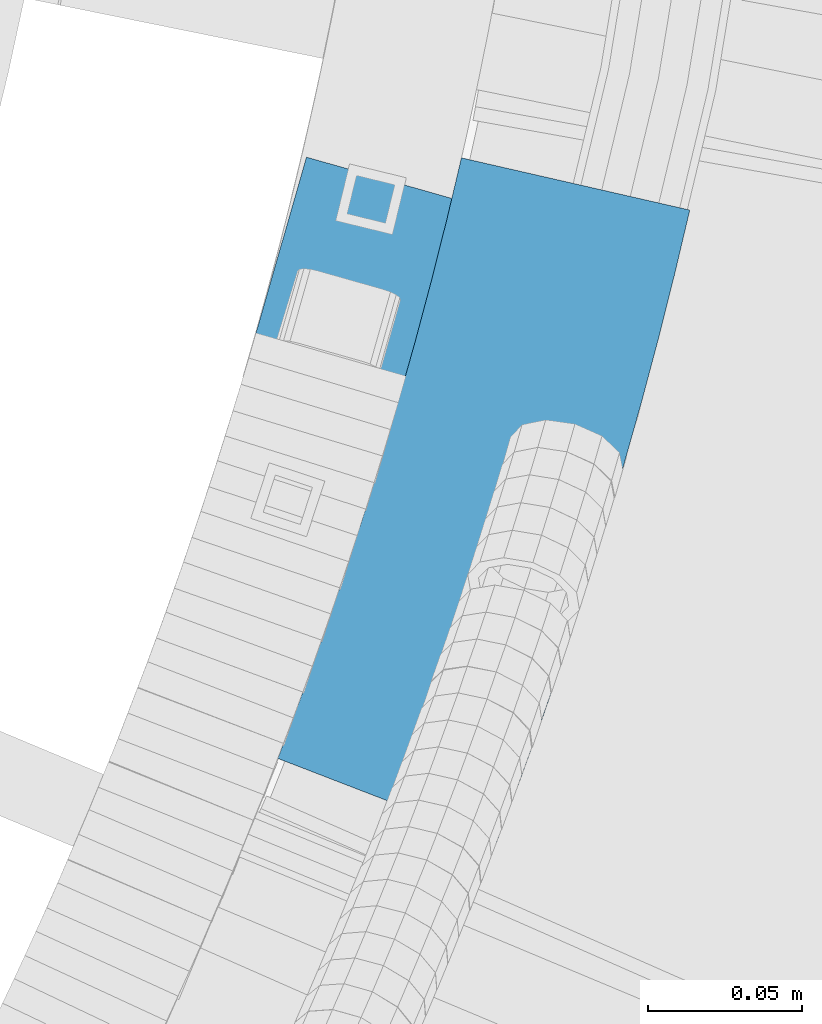
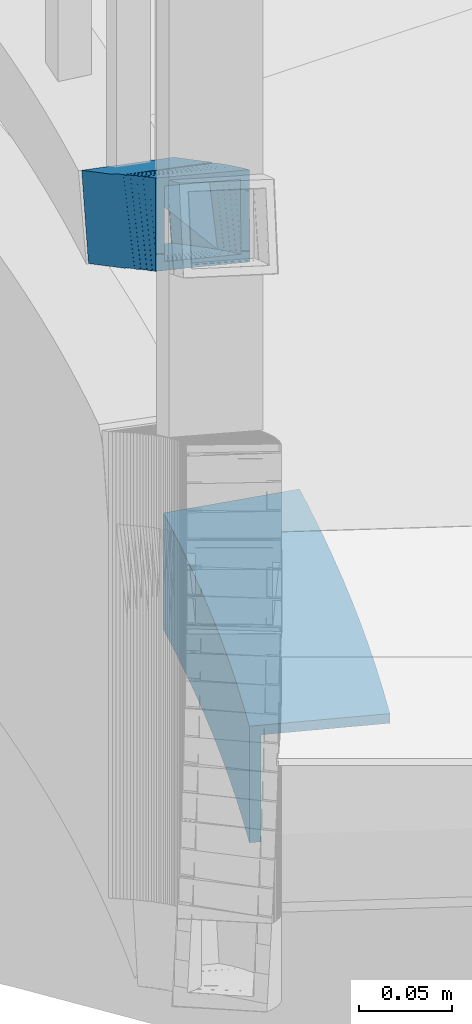
# One storey, part 494 of 975: 1 beam, 1 member.
"""IFC2X3 building model written with IfcOpenShell, lengths in millimetres."""

from ifc_helpers import new_model, si_unit, frame, origin_with_axes, place, context, subcontext, project, spatial, faceted_brep, material, type_object, element, save


model = new_model("IFC2X3")

# Units and contexts
model_context = context("Model", 3, precision=1e-05, world=origin_with_axes())
body_context = subcontext(model_context, "Body", "Model", "MODEL_VIEW")
ifc_project = project(units=[si_unit("LENGTHUNIT", "METRE", prefix="MILLI"), si_unit("AREAUNIT", "SQUARE_METRE"), si_unit("VOLUMEUNIT", "CUBIC_METRE"), si_unit("MASSUNIT", "GRAM", prefix="KILO"), si_unit("TIMEUNIT", "SECOND"), si_unit("PLANEANGLEUNIT", "RADIAN"), si_unit("SOLIDANGLEUNIT", "STERADIAN"), si_unit("THERMODYNAMICTEMPERATUREUNIT", "DEGREE_CELSIUS"), si_unit("LUMINOUSINTENSITYUNIT", "LUMEN")], contexts=[model_context])

# Site, building, storey
site_placement = place(None, origin_with_axes())
site = spatial("IfcSite", under=ifc_project, at=site_placement, CompositionType="ELEMENT")
building_placement = place(site_placement, origin_with_axes())
building = spatial("IfcBuilding", under=site, at=building_placement, Name="Undefined", CompositionType="ELEMENT")
storey_placement = place(building_placement, origin_with_axes())
storey = spatial("IfcBuildingStorey", under=building, at=storey_placement, Name="Undefined", CompositionType="ELEMENT", Elevation=0.0)

# Member
ifc_material_1 = material()
member_type = type_object("IfcMemberType", Name="HSS2X2X.188_TUBES", PredefinedType="NOTDEFINED")
member_placement = place(storey_placement, frame((36058.6682206179, 2958.69958421082, 2375.71879343567), z_axis=(0.95087143147721, -0.309586047490001, 4.0258373701363e-10), x_axis=(-0.260603277001165, -0.800424350003793, 0.539821074002544)))
element("IfcMember", 1, at=member_placement, inside=storey, type_object=member_type, material=ifc_material_1, Name="HANDRAIL", ObjectType="HSS2X2X.188_TUBES", context=body_context, shape_type="Brep", body=[
    faceted_brep([(85.1909390580277, -20.7696041309646, 18.6765739419134), (85.1843664568114, -14.2400431348069, 18.4890902299958), (89.372431475711, -20.7707783078004, 18.4890902346815), (86.5870745108568, -21.9558293144728, -22.6854508030738), (83.4755373449425, -21.9549555845952, -22.5459402014094), (85.105765746679, -20.8242245320762, 16.7772759879954), (83.4474729527701, -17.0600346618012, -22.6854508065881), (73.2920638491851, -21.643966446667, -22.0919903583708), (62.6296669214062, -21.5914426805666, -21.7448117184031), (63.9768686473708, -20.7275018938362, 19.4991487951556), (74.5513523739428, -20.7795925929222, 19.1548326996854), (74.5502534711177, -20.7801463676842, 19.1283485368185), (74.6383750251989, -20.7805967566092, 19.1247063785704), (64.1435749368338, 18.5945900370571, 18.6700202242719), (74.4250307848615, 2.56201531871739, 18.6700202279899), (74.4185663200496, 2.55106416215494, 18.5133816507441), (73.290057466771, -21.9016800830505, -22.114620653083), (83.4754059197603, -21.855356416494, -22.5382081810531), (83.4483317206668, -17.0585798599532, -22.6646422012054), (73.3733969314217, -1.34804750369585, -22.6646422147605), (74.638267721486, -20.8070605830308, 19.1254145587445), (85.1848827854228, -20.7590938510348, 18.6868027013261), (85.1477469286856, -14.1796782834754, 18.513381665216), (73.3781592835894, -1.33607885985111, -22.5201936656158), (62.7855668053508, 15.1816724079199, -22.5201936694502), (62.628873559408, 14.7878742199428, -27.2729106571787), (62.454034583885, -26.4525270323775, -26.4033334481937), (64.1121290158371, -25.3892152948647, 24.358464106961), (64.3002681827747, 18.9883882250324, 23.4227372120076), (72.5289680790866, -0.650017791800565, -27.2729106535917), (72.5230647418739, -0.660018365455471, -27.415952661795), (72.6677613303273, -26.2961304751861, -26.740232899414), (72.8007416245855, -26.5034956864438, -26.7402328998505), (72.6689279485927, -26.5028219872493, -26.7347848993959), (72.6705544138586, -26.7909852834255, -26.7271894561709), (74.774525943616, -25.4417390609651, 24.0112854670006), (74.8928606610134, 2.4706369572632, 23.4227372158348), (74.887650040926, 2.45754173585556, 23.2646920974512), (85.3438332988408, -13.8474973323446, 23.264692111341), (85.4090010929885, -25.3933727219337, 23.5690196969663), (85.3974666345948, -13.9344469258194, 23.2399988111501), (92.7472297058175, -25.3954333206857, 23.2399988193793), (83.1243980715662, -17.1941398216914, -27.4363593878661), (83.1253134080616, -17.192827183826, -27.4159526474905), (89.3190980567706, -26.8539576365893, -27.4363593809321), (83.1341198147784, -26.8522208743379, -27.1590462749518), (83.1340102687827, -26.7433922336695, -27.162171078824), (83.1847692866704, -26.7431659097347, -27.1644538568071), (83.1339302416145, -26.663889117046, -27.1644538570181), (51.8441843637811, -26.0925731607895, -26.0643109739613), (51.8456197991018, -26.4841812515151, -26.0561548129917), (53.5037142165038, -25.4208695075067, 24.7056427429998), (63.9474467026939, 19.5385667782029, 23.4227372165187), (60.1960984104935, 25.3882997998953, 23.4227372123278), (53.5665815768753, 25.3685181279743, 23.6396995601026), (51.6719750990324, 24.3124925469056, -26.73063740004), (51.6594545590633, 24.3044633073387, -27.1139479749472), (51.843149890763, -25.8103535455957, -26.0701888622498), (52.5250634735276, 24.3152517441958, -26.7482963453003), (56.5167295814663, 24.3189568252419, -27.2729106594197), (52.0243446479217, -26.0929028673927, -26.0701888622643), (62.3009942566168, 15.299158757769, -27.2729106529732), (62.455349173435, 15.6966032596829, -22.5201936652156), (62.5920279778948, -21.5914061291442, -21.7435830331015), (63.9392296725709, -20.7274653423665, 19.5003774813595), (63.7930917858739, 19.1411222762872, 18.6700202287466), (62.8987982159997, 20.5356551800069, 18.6700202277498), (59.9093110424146, 19.6668140131023, -22.5201936680533), (53.3318635353226, -20.7217304042624, 19.883008736826), (53.1909164933968, 20.5499242483929, 19.3391887806065), (51.8424911728198, 20.0041418235342, -21.9131526543206), (51.8437006390504, 19.6499898537022, -21.9084861365845), (53.1795555943772, 20.506654142122, 18.9880991693499), (53.3306795589251, -20.7222096250971, 19.8467873770642), (52.6168119806807, 19.6524903762511, -21.9244895557713), (52.6094368717677, 19.6450320764197, -22.2812927227351), (52.55835714145, -21.6213453825803, -21.415213887034), (53.411202767029, -20.7588796941873, 19.8449252805804), (53.4112479749183, -20.7223570712376, 19.8441587613779), (31.3093052156873, 20.4406211395362, -21.1126368639234), (31.6733231854414, 20.6740605650175, 20.160097743501), (21.5243876892109, 20.5785127107119, 20.2501499187201), (21.037008749925, 20.3439118948627, -21.0214900986684), (32.0639268345767, -20.5984503467153, 20.3900908510332), (21.3934873952003, -20.6989079359191, 20.4847703651976), (31.6999088648245, -20.8318897722002, -20.8826437563912), (20.983529829673, -20.9327798628983, -20.787556617157), (21.3474680553481, -20.6993915761323, 20.4761365241138), (21.3933789933435, -20.6989601153655, 20.4755908089428), (20.9538765718989, 25.3623185901506, 24.9908858250274), (20.9530288038368, 25.3617749288314, 24.8947650035989), (21.4346195246817, -25.4346179166005, 25.273954265067), (42.9560500855441, 25.3909811661524, 24.1475024120009), (32.4630791062827, 25.4592838163444, 24.3961960057859), (32.150998569814, -25.3337278255949, 25.178867123228), (42.7873351813068, -25.4029636889354, 24.9267756332338), (42.8561748845441, 25.3911522082835, 24.1498768633173), (42.8513105204129, 25.3880327625593, 23.9143962278467), (41.8090811184884, 24.6171227157447, -26.5309333764453), (41.8932922790664, 24.6165786147194, -26.5326657331316), (41.8908423464618, 24.6150075087353, -26.6356026870562), (31.254505746374, 24.6842433790662, -26.3835111889566), (41.5787618099966, -26.1780041332022, -25.8529315696214), (30.9424252099088, -26.1087682628695, -25.6008400715218), (30.9453781973771, -25.6281515329501, -25.6082459098616), (31.1694421837183, -25.6260608831726, -25.6136106139456), (30.9475173076316, -25.2799982857905, -25.6136106142148), (20.986597408064, -25.7219279787314, -25.5232575594637), (31.6702556070504, 25.4632086808506, 24.8957986858004), (20.5058544552794, 25.0750085280179, -25.8063259994815), (20.5067431948974, 24.981101275429, -25.8058026966901), (20.9349325403291, 25.3501700584457, 22.8429918955881), (31.2222334904309, 25.1758986187178, -25.901413138723), (21.2664451055298, 25.3647203454057, 24.891039616261), (20.8728784055929, -13.705991156965, -25.5902169614492), (20.9955591823364, 24.9795294917003, -25.8101050742334), (31.2502520708895, 22.215360051734, -25.8849153911942), (10.3040858872137, 25.0134069994092, -25.7817800186676), (10.1462176635378, -25.1277620030451, -25.4000000000597), (10.3085966870822, 25.0162997096049, -25.4000000000087), (20.9944045946904, 24.9787890714742, -25.9078257680812), (10.7443008148512, 25.0149279059915, -25.4000000000015), (10.7443008148275, 25.2957104147681, 11.4766371525693), (10.9042379470629, 25.3982757660124, 25.0132167189877), (10.7443008391474, -25.3999999803054, 25.4000000159358), (10.1441487792981, -25.7848687469068, -25.3949967217195), (20.8344674867767, -25.8194866748399, -25.5210424711331), (10.1453605289753, -25.3999999999978, -25.397927151942), (10.3207999221213, -25.3999999999978, -25.4000000000597), (0.0, 25.3999999999724, -25.4000000000342), (1.2732925824821e-11, 25.3051002816392, -25.4000000000378), (-2.18278728425503e-11, 25.3999999999869, 25.0401471488367), (-10.5679539465345, 25.3557880582484, -25.4643129099131), (-10.8083039031917, -24.6357178351973, -25.370257279872), (-10.5665843539682, 25.3566663581878, -24.9939878685545), (20.5929637581012, 20.2539657761263, -21.1043140418769), (10.7443008148493, 20.2858582120152, -20.9881919565232), (10.7443008148566, -20.9881616389357, -20.6754627090631), (20.9057258462526, -21.021066876754, -20.7952724610586), (20.9253104442905, -14.8007229901013, -20.8426347992863), (0.0875273161273071, 20.5510763158873, -20.6375000000262), (0.207468504937424, 20.6279928687254, 20.5509132241932), (-10.456789874901, 20.6793229062114, 20.5818718263254), (-10.5757412930725, 20.6030410789954, -20.2666491357959), (-10.2781924243536, 20.6016170200128, -20.2631936834732), (-10.2731638156674, 20.6007827560279, -20.6937631977853), (9.09494701772928e-12, 20.5513351653008, -20.7235864428585), (9.09494701772928e-12, 20.5514971311077, -20.6375000000262), (-7.27595761418343e-12, -20.6522469299762, 17.5281188893059), (-0.111164062889657, -20.7235348386694, -20.6461847268583), (-10.1417332690216, -20.6752549231751, -20.6170657398616), (-10.6238003142407, -20.5952782936383, 20.6594356657079), (-1.09139364212751e-11, -20.6464135952192, 20.6285945143391), (1.2732925824821e-11, 2.39799587925881, -20.6896863197835), (-1.09139364212751e-11, -20.6375000000044, 20.6285778688034), (0.0, -20.6375000000153, -20.6375000000153), (1.45519152283669e-11, 5.2389197220582, -25.4000000000524), (0.0, -25.400000000016, -25.4000000000196), (0.0, -25.399999999976, 25.4000000000378), (10.7035700606884, -20.6375000000116, 20.6375000000626), (0.0090975902548962, -20.6375000000044, 20.6375000000335), (0.20776562892388, 20.637499999988, 20.6375000000771), (10.7443008148221, 20.6374999999807, 20.637500000099), (10.7443008148257, -8.05948712242025, 20.6375000000771), (10.7443008148275, -20.6375000000116, 20.6009459134075), (10.7443008148566, -20.6375000000007, -20.6375000000407), (0.00907161240138521, -20.6375000000044, 20.628551452166), (10.7031447978261, -20.6375000000116, 20.6014321791808), (10.7443008148275, -20.6738767189581, 20.6012215362862), (10.744300814853, 20.2885284166478, -20.6374999999971), (10.3494439513215, 20.2897716136649, -20.6374999999971), (10.3505699828747, 20.6374999999935, -20.6374999999898), (0.0879432973233634, 20.6375000000007, -20.6375000000262), (10.7443008148275, 20.6374999999825, 12.7559947902191), (-10.6239431577833, -20.5504179812815, 20.6593523081028), (-10.6550153736152, -20.5505209643288, 20.6594429831021), (-10.8121877390167, -25.4435349212654, -25.3687374267902), (-10.6642583710964, -25.3486699532186, 25.4309586114905), (-10.8099187961288, -24.9716069321566, -25.3696253273083), (-21.6298011319632, 25.4150339108164, 25.682438672884), (-21.6287561402187, 25.415704048688, 25.5927306503145), (-21.4625412938931, -25.3832878961675, 25.3049128607236), (-10.8315182098777, 25.44965185613, 25.8084844262921), (-20.8708383800476, -25.0038374999604, -25.4902237674396), (-10.5933634094308, -24.9708891998398, -25.3702572796974), (-21.3824672894934, -20.5741279225313, 17.1241930513279), (-21.4226239146519, -20.5937356752238, 20.5697782314382), (-21.42265148769, -20.5853087343912, 20.5698259769488), (-20.9419911380392, -20.2770683052004, -20.6927866636615), (-21.0776220182834, 20.9152536595284, -20.3866512589666), (-21.0766732942575, 20.9157169042846, -20.4680552473583), (-21.0134374104528, 1.5894098774952, -20.5775545641955), (-20.9674867850426, 4.34915503934099, -25.2720765540435), (-32.1313067239462, -20.5770384794214, 20.4747758715966), (-32.0690412009008, 20.6972421127684, 20.7103806287341), (-21.3508007138153, 20.6805300144406, 20.80546777977), (-21.0465478851638, -20.3587077457232, -20.7028403559234), (-31.6598628860465, -20.3421592493451, -20.7969966577657), (-32.1007077765789, -20.5574158242052, 17.0291059004812), (-31.7025228492021, 20.9322849447944, -20.562322749829), (-32.1807817864155, -25.3665757976014, 25.2098257125253), (-32.1041472965153, 25.4325387774006, 25.4998007982431), (-31.6530477867327, 25.7218222629726, -25.2973725907577), (-31.7294494322814, -24.9229455288332, -25.586466623281), (-31.6857272722045, 4.3658671330486, -25.3671636970321), (-31.7316778975401, 1.606121975934, -20.6726417152313), (-32.1409902427349, -20.5686596486212, 20.4831747038115), (-31.6602316252356, -20.2603562017011, -20.7878738065701), (-42.008370110525, -20.2935310402154, -20.9086651324978), (-42.8531681251225, -20.6030015519391, 20.3581340337696), (-31.7961302436706, 21.0132802664739, -20.4811340841916), (-32.2768888611645, 20.7049768195538, 20.7899144261901), (-43.07517178325, 20.6703588742421, 20.6638686727747), (-42.5974128864127, 20.97673864432, -20.3496667898798), (-41.7674862465174, 20.9793445469259, -20.3326138734847), (-41.7620643361406, 20.981330727469, -20.597464030383), (-52.4666938933588, 26.12757556615, -25.2482260164252), (-52.7609764475183, -24.1736832686802, -25.9157388076856), (-52.4726417210841, 26.1237613113935, -24.95817590761), (-42.5546216273997, 25.7765784652111, -25.3338308516104), (-42.3889996191901, -24.5243196364681, -25.7076598824278), (-42.5579316639851, 25.7744557873193, -25.0496785235373), (-42.8218383615094, 25.398168331134, 25.4650934255114), (-32.348041619156, 25.4317460143156, 25.5873515299609), (-31.7563387053124, 25.8111964105246, -25.2077850982023), (-41.6421505427516, 25.7773312660629, -25.0308615123213), (-42.6710502173264, 25.40041974011, 25.2289585859617), (-31.7296822766348, -25.0772923120312, -25.5873476764682), (-31.7295469333312, -24.987576574229, -25.5868355547718), (-42.9790647031732, -25.4011937379837, 25.0837799643996), (-42.3873617893278, -25.0217433417765, -25.7113566637709), (-31.6880882684181, -24.9874428082258, -25.5864666232301), (-42.3883203762507, -24.7306118455945, -25.709193016417), (-52.7638630336605, -24.667082943768, -25.9222863693576), (-53.8052694179623, -25.3349215964899, 24.8626470687886), (-52.7621660319928, -24.3770170911703, -25.9184371084993), (-42.2561987053432, -24.7314051555477, -25.7076598823187), (-53.5081002776606, 25.4597369134281, 25.5367074217211), (-42.6818955759536, 25.3934647705591, 25.7578403215157), (-42.6759271673782, 25.3972922235116, 25.4667865726151), (-41.6404891916518, 26.0613034232792, -25.0270931166306), (-52.3450519774215, 26.1229652397669, -24.9544366994378), (-52.7662551067806, 25.9354713499724, -10.6399073873035), (-52.6306049839422, -24.3769803650503, -25.91573880738), (-148.36852020388, 26.403354666747, -27.7745622173534), (-150.048616437696, 25.4453572875445, 22.9889506606996), (-53.8390841225573, 25.4560446140331, 25.8200433926322), (-52.3452457515723, 26.414021302995, -24.948950369384), (-133.652967455984, -24.3859806420478, -28.2999289806321), (-135.333063689799, -25.3439780212502, 22.4635838974282), (-53.6696186965764, -18.6412059819104, 20.2275357787148), (-53.6958666462342, 20.7842018461579, 20.9706943221972), (-52.8597819034785, 21.3203707578105, -7.44414754693571), (-53.6801795843458, -20.4834595112679, 20.1924629505302), (-136.555137737996, -20.4926655817508, 17.7537576991672), (-148.51152434566, 20.7736693566458, 18.1806181943248), (-135.19005954802, -19.714292711149, -23.4915965142573), (-147.146446155682, 21.5520422272475, -23.0647360190997), (-52.5960676927043, 21.5625452485183, -20.282466083605), (-53.4383280360362, 20.7603475518154, 20.7124267538093), (-53.6796178438617, -20.4829436527725, 20.1651159096946), (-52.5975755676664, 21.2995097887797, -20.2874737534803), (-53.6675845848495, -20.4829402936102, 20.1653627103806), (-52.4546485181017, -19.7051021421012, -21.0569976215702), (-52.4819473619846, 21.298788348864, -20.2840850960492), (-43.0782938553093, 20.6969290515881, 20.9240377905007), (-52.4741840135684, 21.3022441170942, -20.5479214038278), (-42.5983030781827, 21.2417893399725, -20.3461995401231), (-42.9396755695943, -20.576057558812, 20.3841269162149), (-53.6675709231622, -20.5103872123545, 20.1650020544694), (-52.4536407700707, -19.9700197020502, -21.0902440445061), (-42.0074305735798, -20.0339657250261, -20.8768728016366), (-42.9393639548907, -20.5757038301854, 20.3573338746428), (-42.8530083214664, -20.576222343032, 20.3583359416298), (-20.9348072996472, 25.7051101646466, -25.2022854397292), (-21.0114417895493, -25.0940044103572, -25.4922605254324), (-21.5240097434053, 25.4160420119752, 25.5936627654737), (-21.6254745836359, 25.4178084627729, 25.3110232069448), (-10.2398152960341, 25.8291022523408, -24.9866522018783), (-21.0380982181177, 25.7944843070254, -25.1126979552937), (-21.0378027828756, 25.7047579583668, -25.1133647885872), (-20.98488550605, 20.9968663229774, -20.3849613250932), (-20.9850075546838, 20.9151077911338, -20.385573500309), (-21.3515146541849, 20.6889287608719, 20.8874193910742), (-21.4131286310385, -20.5853409079955, 20.578374151788), (-10.1437082159573, -20.2424503598868, -20.5667409102462), (-10.6548877515434, -20.5508513324676, 20.7039525040964), (-10.5736757155955, 21.0302433602137, -20.2634337830241), (-10.5155817828436, 20.8798588364589, -0.0025722194914124), (-10.7603654518862, 20.72288266137, 21.0110473225141), (-10.6367904282324, -16.8079668914797, 20.7321234534902), (-10.4200245786124, 25.4506530262952, 25.3353831283603), (-10.5010486594256, 25.3986934529839, -2.48869761304377), (-10.238254567721, 25.3550949827622, -24.9901749556448), (0.0963044333020662, 25.3044580207606, -25.4952715120307), (-0.147929359181944, -25.4948649587532, -25.3996960289005), (0.0965818651693553, 25.3046359338132, -25.4000000000306), (0.0, 25.400000000016, 25.4000000000196), (-2.18278728425503e-11, 25.3999999999869, 25.3051344739361), (0.103578884953095, 25.3999999999869, 25.3048328508885), (10.7443008148184, 25.3999999999796, 25.4000000001179), (10.7443008148548, 25.3999999999942, -25.4000000000015), (10.8329795875852, 20.5998559679265, 20.2874467089205), (21.347551686702, -20.7082126994464, 20.4762023727817), (21.523298295062, 20.5652380399915, 20.1614009595069), (21.2137716012039, -20.8235216249814, 5.27675855334383), (20.5937316008076, 20.2546276019657, -21.0170754815263), (21.0367210914865, 20.253203172957, -21.0209745112006), (32.0622263607929, -20.6475737442815, 20.1463251240202), (31.7037065857239, -21.2782908594872, -20.9282822053574), (31.3272275203781, 18.1519387878652, -21.5211375312429), (31.338551948571, 19.9950585786301, -21.5495382221925), (32.3205178034968, 20.6247789339159, 19.7089738735376), (32.066952367617, -20.644543025157, 20.3448941564493), (42.695438043278, -20.7040862948616, 20.0928415766684), (42.6954249765695, -20.7137277058464, 20.0929890425759), (42.9568544035847, 20.555543063585, 19.456882375438), (42.7033484373878, -20.7040998418743, 20.0926535135077), (42.6436481558867, -20.7520256766984, 17.5869200520028), (41.7213231127826, -21.3434992507755, -21.1657094373732), (41.7845490469062, 7.05573637198177, -26.2977884116845), (41.8773555279477, 4.05172843577202, -21.5570253012775), (41.8988698704361, 19.9263175421438, -21.7998280038591), (41.9771088001016, 19.9272465231079, -21.708343105005), (41.9007924368743, 19.9277396146554, -21.7067731567731), (41.9776870326896, 20.0206247598508, -21.7095920445354), (42.9591437185682, 20.5670203464651, 19.5503218021622), (42.7035784662748, -20.7039717804237, 20.1023238047055), (52.5596481527809, -21.2684756086728, -21.381222812146), (41.843269117584, -21.2505697900997, -21.1600899219266), (41.7382666438007, -26.0757160316189, -25.8579352502347), (41.8092244933323, 24.7197582019089, -26.532295965153), (52.5256035285329, 24.7018523833358, -26.753428855387), (42.8582930308403, 25.3925105445924, 24.2524149183082), (53.5746720660372, 25.3746047260192, 24.0312820280742)], [[[0, 1, 2]], [[0, 2, 3, 4, 5]], [[3, 6, 4]], [[7, 8, 9, 10, 11, 12]], [[9, 13, 14, 10]], [[10, 14, 15, 11]], [[16, 17, 18, 19]], [[20, 21, 17, 16]], [[12, 11, 15, 22, 21, 20]], [[16, 19, 23, 7, 12, 20]], [[8, 7, 23, 24]], [[9, 8, 24, 25, 26, 27, 28, 13]], [[29, 30, 31]], [[26, 25, 29, 31, 32]], [[33, 34, 35]], [[27, 26, 32, 33, 35]], [[27, 35, 36, 28]], [[36, 35, 37]], [[38, 22, 15, 14, 13, 28, 36, 37]], [[35, 39, 38, 37]], [[5, 4, 6, 18, 17, 21, 22, 38, 39]], [[40, 1, 0, 5, 39]], [[39, 41, 40]], [[42, 43, 30, 29, 25, 24, 23, 19, 18, 6, 3, 2, 1, 40, 41, 44]], [[39, 45, 44, 41]], [[42, 44, 45, 46, 47, 48]], [[42, 48, 43]], [[47, 34, 33, 32, 31, 30, 43, 48]], [[46, 39, 35, 34, 47]], [[45, 39, 46]], [[49, 50, 51]], [[51, 50, 26, 27]], [[51, 27, 52, 53, 54]], [[55, 56, 57]], [[58, 54, 53, 59, 56, 55]], [[60, 57, 56, 59, 61, 26, 50, 49]], [[27, 26, 61, 62, 63, 64, 65, 52]], [[66, 67, 62, 61, 59, 53, 52, 65]], [[68, 69, 70, 71, 72, 73]], [[74, 75, 67, 66, 72, 71]], [[76, 63, 62, 67, 75]], [[77, 64, 63, 76]], [[78, 73, 72, 66, 65, 64, 77]], [[79, 80, 81, 82]], [[80, 83, 84, 81]], [[83, 85, 86, 87, 88, 84]], [[89, 90, 91]], [[92, 93, 94, 95, 96]], [[97, 98, 99, 100, 101, 93, 92]], [[101, 100, 102, 103, 104, 105, 106]], [[94, 103, 102, 95]], [[103, 94, 104]], [[104, 94, 91, 107, 105]], [[89, 91, 94, 108]], [[109, 110, 111]], [[89, 108, 112, 109, 111, 113, 90]], [[106, 105, 107, 114, 115, 110, 109, 112, 116]], [[117, 118, 119]], [[111, 110, 115, 120, 117, 119, 121, 122, 123, 113]], [[90, 113, 123, 124, 91]], [[124, 125, 126, 91]], [[125, 124, 127]], [[117, 120, 126, 125, 127, 128, 118]], [[129, 130, 131]], [[132, 133, 134]], [[135, 136, 137, 138, 139]], [[140, 141, 142, 143, 144, 145, 146, 147]], [[148, 149, 150, 151, 152]], [[146, 145, 150, 149, 153]], [[152, 154, 155, 147, 146, 153, 156, 157, 158, 148]], [[159, 160, 161, 162, 163]], [[164, 165, 155, 154, 166, 160, 159, 167]], [[168, 137, 136, 169, 165, 164]], [[170, 171, 172, 140, 147, 155, 165, 169]], [[173, 162, 161, 172, 171]], [[160, 166, 141, 140, 172, 161]], [[154, 152, 151, 174, 175, 142, 141, 166]], [[176, 177, 178]], [[179, 180, 181]], [[179, 181, 177, 182]], [[178, 177, 181, 183, 184]], [[183, 181, 185, 186, 187, 188, 189, 190, 191, 192]], [[186, 185, 193, 194, 195, 187]], [[181, 196, 197, 198, 193, 185]], [[199, 194, 193, 198, 200, 201, 202, 203, 204, 205]], [[206, 207, 208, 209]], [[210, 211, 212, 213, 214, 215]], [[216, 217, 218]], [[219, 220, 221]], [[222, 223, 224, 219, 221, 225, 226]], [[227, 200, 228]], [[228, 200, 229, 230, 231]], [[230, 229, 232]], [[233, 234, 235]], [[232, 229, 234, 233, 236]], [[237, 234, 229, 238]], [[239, 238, 229]], [[200, 223, 222, 239, 229]], [[226, 240, 216, 218, 241, 242, 237, 238, 239, 222]], [[225, 240, 226]], [[221, 220, 236, 233, 235, 243, 217, 216, 240, 225]], [[244, 245, 246, 247]], [[218, 217, 243, 248, 244, 247, 241]], [[235, 234, 249, 248, 243]], [[245, 249, 234, 246]], [[242, 241, 247, 246, 234, 250, 251, 252]], [[253, 254, 255, 251, 250]], [[248, 249, 245, 244], [255, 254, 256, 257]], [[252, 251, 255, 257, 258]], [[259, 260, 253, 250, 234, 237, 242, 252, 258, 261]], [[262, 263, 256, 254, 253, 260]], [[261, 258, 257, 256, 263, 264]], [[265, 259, 261, 264, 266, 267]], [[268, 269, 262, 260, 259, 265]], [[270, 266, 264, 263, 262, 269]], [[213, 267, 266, 270, 271, 214]], [[212, 272, 268, 265, 267, 213]], [[273, 271, 270, 269, 268, 272]], [[212, 211, 206, 209, 273, 272]], [[208, 215, 214, 271, 273, 209]], [[207, 210, 215, 208]], [[198, 197, 205, 204, 224, 223, 200], [206, 211, 210, 207]], [[203, 231, 230, 232, 236, 220, 219, 224, 204]], [[202, 274, 275, 227, 228, 231, 203]], [[200, 227, 275, 180]], [[276, 277, 201, 200, 180]], [[179, 182, 278, 279, 277, 276, 180]], [[279, 280, 277]], [[192, 274, 202, 201, 277, 280]], [[191, 190, 196, 181, 180, 275, 274, 192]], [[189, 199, 205, 197, 196, 190]], [[281, 195, 194, 199, 189, 282]], [[283, 284, 187, 195, 281]], [[174, 285, 188, 187, 284, 286, 175]], [[151, 150, 145, 144, 285, 174]], [[143, 287, 281, 282, 189, 188, 285, 144]], [[288, 289, 283, 281, 287]], [[286, 284, 283, 289, 290]], [[287, 143, 142, 175, 286, 290, 177, 291, 292, 288]], [[293, 278, 182, 177, 290, 289, 288, 292]], [[134, 133, 184, 183, 192, 280, 279, 278, 293]], [[132, 294, 295, 176, 178, 184, 133]], [[156, 153, 149, 148, 158, 295, 294, 296]], [[177, 176, 295, 158]], [[297, 298, 158]], [[299, 291, 177, 158, 298]], [[131, 130, 296, 294, 132, 134, 293, 292, 291, 299]], [[298, 297, 300, 301, 129, 131, 299]], [[119, 118, 128, 157, 156, 296, 130, 129, 301, 121]], [[127, 124, 158, 157, 128]], [[297, 158, 124, 300]], [[163, 162, 173, 122, 121, 301, 300, 124]], [[123, 122, 173, 171, 170, 302, 167, 159, 163, 124]], [[87, 303, 168, 164, 167, 302, 304, 88]], [[305, 138, 137, 168, 303]], [[91, 126, 120, 115, 114, 139, 138, 305]], [[303, 87, 86, 306, 135, 139, 114, 107, 91, 305]], [[307, 304, 302, 170, 169, 136, 135, 306]], [[82, 81, 84, 88, 304, 307]], [[306, 86, 85, 79, 82, 307]], [[308, 309, 310, 116, 112, 108, 94], [83, 80, 79, 85]], [[93, 101, 106, 116, 310, 311, 312, 313, 308, 94]], [[314, 315, 313, 312, 316, 317]], [[318, 319, 309, 308, 313, 315]], [[95, 102, 100, 99, 320, 321, 319, 318]], [[322, 311, 310, 309, 319, 321]], [[323, 316, 312, 311, 322, 324]], [[325, 326, 327, 317, 316, 323]], [[326, 325, 70, 69]], [[76, 75, 74, 328, 78, 77]], [[70, 325, 323, 324, 329, 328, 74, 71]], [[57, 60, 330, 320, 99, 98, 331, 332, 58, 55]], [[331, 98, 97]], [[333, 334, 332, 331, 97, 92, 96]], [[333, 96, 95]], [[333, 95, 51, 334]], [[332, 334, 51, 54, 58]], [[95, 330, 60, 49, 51]], [[315, 314, 329, 324, 322, 321, 320, 330, 95, 318]], [[328, 329, 314, 317, 327, 68, 73, 78]], [[327, 326, 69, 68]]]),
])

# Beam
ifc_material_2 = material(Name="STEEL/A36")
beam_type = type_object("IfcBeamType", Name="L3X3X1/4", PredefinedType="NOTDEFINED")
beam_placement = place(storey_placement, frame((36096.8705560817, 2877.65313054303, 2044.7), z_axis=(0.956308835408503, -0.292358361124893, 0.0), x_axis=(0.292358361124894, 0.956308835408502, 0.0)))
element("IfcBeam", 2, at=beam_placement, inside=storey, type_object=beam_type, material=ifc_material_2, Name="ANGLE", ObjectType="L3X3X1/4", context=body_context, shape_type="Brep", body=[
    faceted_brep([(-2.73671066615134, 38.0999999999999, 38.0015843714209), (-2.73671066615134, 31.75, 38.0015843714209), (18.7586199473444, 31.75, 39.3943285454152), (18.7586199473444, 38.0999999999999, 39.3943285454152), (2.28059222179581, 31.75, -31.6679869761792), (2.28059222179581, -38.0999999999999, -31.6679869761792), (22.7737075112873, -38.0999999999999, -30.3401792099467), (22.7737075112873, 31.75, -30.3401792099467), (2.73671066615498, -38.0999999999999, -38.0015843714136), (2.73671066615498, 38.0999999999999, -38.0015843714136), (23.1387154716467, 38.0999999999999, -36.6796799149743), (23.1387154716467, -38.0999999999999, -36.6796799149743), (40.2717532976203, 31.75, 40.4778727166195), (40.2717532976203, 38.0999999999999, 40.4778727166195), (43.2837954886527, -38.0999999999999, -29.3071550606037), (43.2837954886527, 31.75, -29.3071550606037), (43.5576175060196, 38.0999999999999, -35.6512484948908), (43.5576175060196, -38.0999999999999, -35.6512484948908), (61.7982419218315, 31.75, 41.2519928813053), (61.7982419218315, 38.0999999999999, 41.2519928813053), (63.8066160530816, -38.0999999999999, -28.5691280877727), (63.8066160530816, 31.75, -28.5691280877727), (63.9891955195581, 38.0999999999999, -34.9165027213312), (63.9891955195581, -38.0999999999999, -34.9165027213312), (83.3336355961674, 31.75, 41.7165290036937), (83.3336355961674, 38.0999999999999, 41.7165290036937), (84.337926471524, -38.0999999999999, -28.1262508655782), (84.337926471524, 31.75, -28.1262508655782), (84.4292256420085, 38.0999999999999, -34.4755944900608), (84.4292256420085, -38.0999999999999, -34.4755944900608), (104.873482255854, 31.75, 41.8713850490967), (104.873482255854, 38.0999999999999, 41.8713850490967), (104.873482255798, -38.0999999999999, -27.9786149511201), (104.873482255798, 31.75, -27.9786149511201), (104.873482255793, 38.0999999999999, -34.3286149511332), (104.873482255793, -38.0999999999999, -34.3286149511332), (126.41332891554, 31.75, 41.7165290037519), (126.41332891554, 38.0999999999999, 41.7165290037519), (125.409038040074, -38.0999999999999, -28.12625086552), (125.409038040074, 31.75, -28.12625086552), (125.317738869575, 38.0999999999999, -34.4755944900025), (125.317738869575, -38.0999999999999, -34.4755944900025), (147.948722589874, 31.75, 41.2519928814218), (147.948722589874, 38.0999999999999, 41.2519928814218), (145.940348458515, -38.0999999999999, -28.5691280876563), (145.940348458515, 31.75, -28.5691280876563), (145.757768992025, 38.0999999999999, -34.9165027212002), (145.757768992025, -38.0999999999999, -34.9165027212002), (169.475211214081, 31.75, 40.4778727168086), (169.475211214081, 38.0999999999999, 40.4778727168086), (166.463169022942, -38.0999999999999, -29.3071550604291), (166.463169022942, 31.75, -29.3071550604291), (166.189347005566, 38.0999999999999, -35.6512484947234), (166.189347005566, -38.0999999999999, -35.6512484947234), (190.988344564355, 31.75, 39.3943285456626), (190.988344564355, 38.0999999999999, 39.3943285456626), (186.973257000305, -38.0999999999999, -30.3401792097065), (186.973257000305, 31.75, -30.3401792097065), (186.608249039937, 38.0999999999999, -36.6796799147414), (186.608249039937, -38.0999999999999, -36.6796799147414), (212.483675177849, 38.0999999999999, 38.0015843717338), (207.010253845423, 38.0999999999999, -38.0015843711153), (212.483675177849, 31.75, 38.0015843717338), (207.466372289793, 31.75, -31.6679869758736), (207.466372289793, -38.0999999999999, -31.6679869758736), (207.010253845423, -38.0999999999999, -38.0015843711153)], [[[0, 1, 2, 3]], [[4, 5, 6, 7]], [[8, 9, 10, 11]], [[8, 5, 4, 1, 0, 9]], [[3, 2, 12, 13]], [[7, 6, 14, 15]], [[11, 10, 16, 17]], [[13, 12, 18, 19]], [[15, 14, 20, 21]], [[17, 16, 22, 23]], [[19, 18, 24, 25]], [[21, 20, 26, 27]], [[23, 22, 28, 29]], [[25, 24, 30, 31]], [[27, 26, 32, 33]], [[29, 28, 34, 35]], [[31, 30, 36, 37]], [[33, 32, 38, 39]], [[35, 34, 40, 41]], [[37, 36, 42, 43]], [[39, 38, 44, 45]], [[41, 40, 46, 47]], [[43, 42, 48, 49]], [[45, 44, 50, 51]], [[47, 46, 52, 53]], [[49, 48, 54, 55]], [[51, 50, 56, 57]], [[53, 52, 58, 59]], [[58, 52, 46, 40, 34, 28, 22, 16, 10, 9, 0, 3, 13, 19, 25, 31, 37, 43, 49, 55, 60, 61]], [[55, 54, 62, 60]], [[54, 48, 42, 36, 30, 24, 18, 12, 2, 1, 4, 7, 15, 21, 27, 33, 39, 45, 51, 57, 63, 62]], [[57, 56, 64, 63]], [[56, 50, 44, 38, 32, 26, 20, 14, 6, 5, 8, 11, 17, 23, 29, 35, 41, 47, 53, 59, 65, 64]], [[59, 58, 61, 65]], [[62, 63, 64, 65, 61, 60]]]),
])

save(model, "model.ifc")
